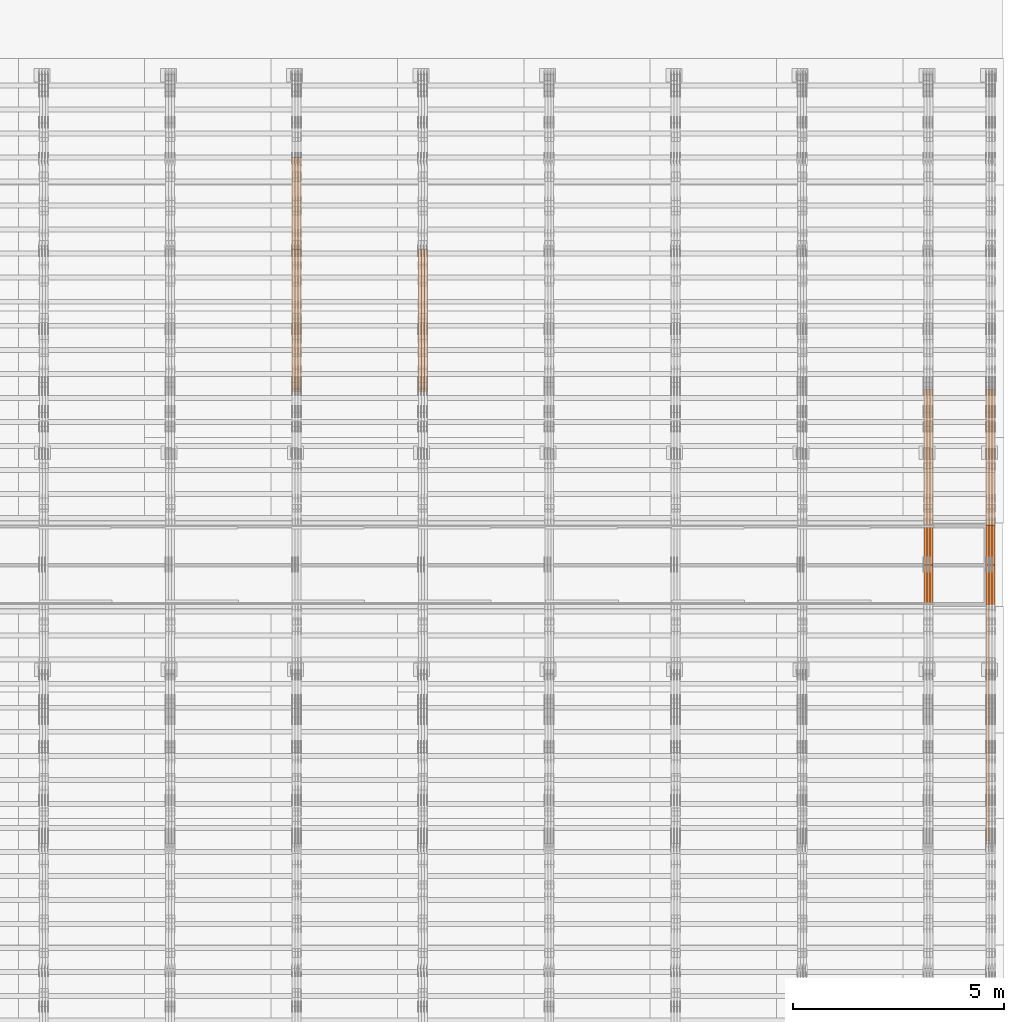
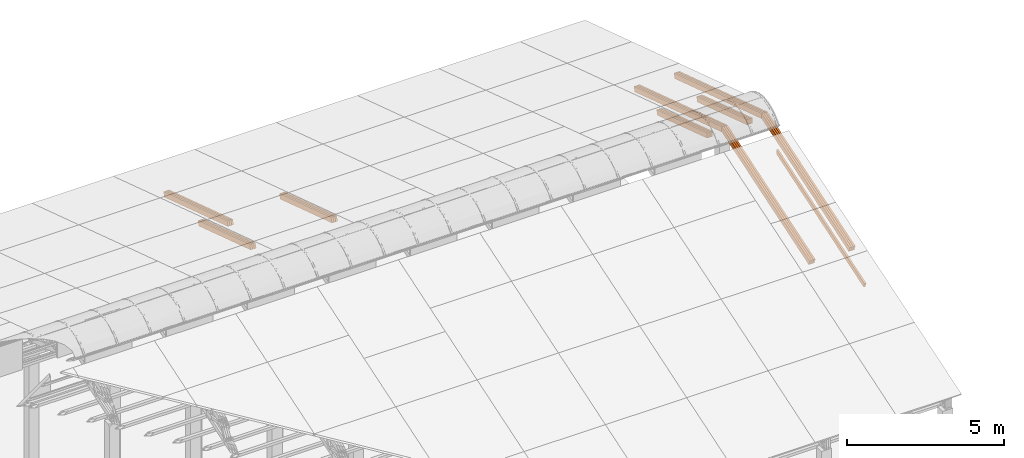
# One storey, part 29 of 385: 28 proxies.
"""IFC2X3 building model written with IfcOpenShell, lengths in millimetres."""

from ifc_helpers import new_model, entity, si_unit, converted_unit, derived_unit, direction, frame, origin, place, context, subcontext, project, spatial, polyline, outline, extrude, source, transform, mapped, material, type_object, type_shapes, element, save


model = new_model("IFC2X3")

# Units and contexts
model_context = context("Model", 3, precision=0.01, world=origin(), true_north=direction((6.12303176911189e-17, 1.0)))
body_context = subcontext(model_context, "Body", "Model", "MODEL_VIEW")
ifc_project = project(units=[si_unit("LENGTHUNIT", "METRE", prefix="MILLI"), si_unit("AREAUNIT", "SQUARE_METRE"), si_unit("VOLUMEUNIT", "CUBIC_METRE"), converted_unit("PLANEANGLEUNIT", "DEGREE", entity("IfcRatioMeasure", 0.0174532925199433), si_unit("PLANEANGLEUNIT", "RADIAN"), dimensions=[0, 0, 0, 0, 0, 0, 0]), si_unit("MASSUNIT", "GRAM", prefix="KILO"), derived_unit("MASSDENSITYUNIT", [(si_unit("MASSUNIT", "GRAM", prefix="KILO"), 1), (si_unit("LENGTHUNIT", "METRE"), -3)]), si_unit("TIMEUNIT", "SECOND"), si_unit("FREQUENCYUNIT", "HERTZ"), si_unit("THERMODYNAMICTEMPERATUREUNIT", "DEGREE_CELSIUS"), derived_unit("THERMALTRANSMITTANCEUNIT", [(si_unit("MASSUNIT", "GRAM", prefix="KILO"), 1), (si_unit("THERMODYNAMICTEMPERATUREUNIT", "KELVIN"), -1), (si_unit("TIMEUNIT", "SECOND"), -3)]), derived_unit("VOLUMETRICFLOWRATEUNIT", [(si_unit("LENGTHUNIT", "METRE"), 3), (si_unit("TIMEUNIT", "SECOND"), -1)]), si_unit("ELECTRICCURRENTUNIT", "AMPERE"), si_unit("ELECTRICVOLTAGEUNIT", "VOLT"), si_unit("POWERUNIT", "WATT"), si_unit("FORCEUNIT", "NEWTON", prefix="KILO"), si_unit("ILLUMINANCEUNIT", "LUX"), si_unit("LUMINOUSFLUXUNIT", "LUMEN"), si_unit("LUMINOUSINTENSITYUNIT", "CANDELA"), derived_unit("USERDEFINED", [(si_unit("MASSUNIT", "GRAM", prefix="KILO"), -1), (si_unit("LENGTHUNIT", "METRE"), -2), (si_unit("TIMEUNIT", "SECOND"), 3), (si_unit("LUMINOUSFLUXUNIT", "LUMEN"), 1)]), derived_unit("LINEARVELOCITYUNIT", [(si_unit("LENGTHUNIT", "METRE"), 1), (si_unit("TIMEUNIT", "SECOND"), -1)]), si_unit("PRESSUREUNIT", "PASCAL"), derived_unit("USERDEFINED", [(si_unit("LENGTHUNIT", "METRE"), -2), (si_unit("MASSUNIT", "GRAM", prefix="KILO"), 1), (si_unit("TIMEUNIT", "SECOND"), -2)])], contexts=[model_context])

# Site, building, storey
site_placement = place(None, origin())
site = spatial("IfcSite", under=ifc_project, at=site_placement, CompositionType="ELEMENT")
building_placement = place(site_placement, origin())
building = spatial("IfcBuilding", under=site, at=building_placement, CompositionType="ELEMENT")
storey_placement = place(building_placement, origin())
storey = spatial("IfcBuildingStorey", under=building, at=storey_placement, Name="Default", CompositionType="ELEMENT", Elevation=0.0)

# Proxies
ifc_material_1 = material(Name="IfcSurfaceStyle #593704")
building_element_proxy_type_1 = type_object("IfcBuildingElementProxyType", Name="T2-T1 593702", PredefinedType="NOTDEFINED", material=ifc_material_1)
shared_shape_1 = source(origin(), body_context, "Body", "SweptSolid", [
    extrude(outline(polyline([(-2970.52406677137, -97.5001477982598), (2938.84461360547, -97.5001477982598), (2938.8441722117, 97.5001477982599), (-2907.1647190458, 97.5001477982598), (-2970.52406677137, -97.5001477982598)])), frame((2938.84461360547, 97.5001477982598, 0.0), z_axis=(0.0, 0.0, 1.0), x_axis=(-1.0, 0.0, 0.0)), (0.0, 0.0, 1.0), 69.9999999999996),
])
type_shapes(building_element_proxy_type_1, [shared_shape_1])
proxy_1_placement = place(building_placement, frame((49860.0, 20279.8851854154, 2416.0025491487), z_axis=(-1.0, 0.0, 0.0), x_axis=(0.0, -0.951056516295154, 0.309016994374948)))
element("IfcBuildingElementProxy", 1, at=proxy_1_placement, inside=storey, type_object=building_element_proxy_type_1, material=ifc_material_1, Name="T2-T1", context=body_context, shape_type="MappedRepresentation", body=[
    mapped(shared_shape_1, transform((0.0, 0.0, 0.0), scale=1.0)),
])
ifc_material_2 = material(Name="IfcSurfaceStyle #593647")
building_element_proxy_type_2 = type_object("IfcBuildingElementProxyType", Name="T2-T1 593645", PredefinedType="NOTDEFINED", material=ifc_material_2)
shared_shape_2 = source(origin(), body_context, "Body", "SweptSolid", [
    extrude(outline(polyline([(-2970.52406677137, -97.5001477982598), (2938.84461360547, -97.5001477982598), (2938.8441722117, 97.5001477982599), (-2907.1647190458, 97.5001477982598), (-2970.52406677137, -97.5001477982598)])), frame((2938.84461360547, 97.5001477982598, 0.0), z_axis=(0.0, 0.0, 1.0), x_axis=(-1.0, 0.0, 0.0)), (0.0, 0.0, 1.0), 69.9999999999996),
])
type_shapes(building_element_proxy_type_2, [shared_shape_2])
proxy_2_placement = place(building_placement, frame((49790.0, 20279.8851854154, 2416.0025491487), z_axis=(-1.0, 0.0, 0.0), x_axis=(0.0, -0.951056516295154, 0.309016994374948)))
element("IfcBuildingElementProxy", 2, at=proxy_2_placement, inside=storey, type_object=building_element_proxy_type_2, material=ifc_material_2, Name="T2-T1", context=body_context, shape_type="MappedRepresentation", body=[
    mapped(shared_shape_2, transform((0.0, 0.0, 0.0), scale=1.0)),
])
ifc_material_3 = material(Name="IfcSurfaceStyle #593590")
building_element_proxy_type_3 = type_object("IfcBuildingElementProxyType", Name="T2-T1 593588", PredefinedType="NOTDEFINED", material=ifc_material_3)
shared_shape_3 = source(origin(), body_context, "Body", "SweptSolid", [
    extrude(outline(polyline([(-2970.52406677137, -97.5001477982598), (2938.84461360547, -97.5001477982598), (2938.8441722117, 97.5001477982599), (-2907.1647190458, 97.5001477982598), (-2970.52406677137, -97.5001477982598)])), frame((2938.84461360547, 97.5001477982598, 0.0), z_axis=(0.0, 0.0, 1.0), x_axis=(-1.0, 0.0, 0.0)), (0.0, 0.0, 1.0), 69.9999999999996),
])
type_shapes(building_element_proxy_type_3, [shared_shape_3])
proxy_3_placement = place(building_placement, frame((49720.0, 20279.8851854154, 2416.0025491487), z_axis=(-1.0, 0.0, 0.0), x_axis=(0.0, -0.951056516295154, 0.309016994374948)))
element("IfcBuildingElementProxy", 3, at=proxy_3_placement, inside=storey, type_object=building_element_proxy_type_3, material=ifc_material_3, Name="T2-T1", context=body_context, shape_type="MappedRepresentation", body=[
    mapped(shared_shape_3, transform((0.0, 0.0, 0.0), scale=1.0)),
])
ifc_material_4 = material(Name="IfcSurfaceStyle #592849")
building_element_proxy_type_4 = type_object("IfcBuildingElementProxyType", Name="T2-T1 592847", PredefinedType="NOTDEFINED", material=ifc_material_4)
shared_shape_4 = source(origin(), body_context, "Body", "SweptSolid", [
    extrude(outline(polyline([(-2938.84391703088, -97.499801613968), (2970.52383457984, -97.499801613968), (2907.16448685427, 97.499801613968), (-2938.84440440323, 97.499801613968), (-2938.84391703088, -97.499801613968)])), frame((2970.52383457984, 97.5000757893295, 0.0), z_axis=(0.0, 0.0, 1.0), x_axis=(-1.0, 0.0, 0.0)), (0.0, 0.0, 1.0), 69.9999999999996),
])
type_shapes(building_element_proxy_type_4, [shared_shape_4])
proxy_4_placement = place(building_placement, frame((49860.0, 14780.2584052475, 4242.0978974122), z_axis=(-1.0, 0.0, 0.0), x_axis=(0.0, -0.951056516295154, -0.309016994374948)))
element("IfcBuildingElementProxy", 4, at=proxy_4_placement, inside=storey, type_object=building_element_proxy_type_4, material=ifc_material_4, Name="T2-T1", context=body_context, shape_type="MappedRepresentation", body=[
    mapped(shared_shape_4, transform((0.0, 0.0, 0.0), scale=1.0)),
])
ifc_material_5 = material(Name="IfcSurfaceStyle #592792")
building_element_proxy_type_5 = type_object("IfcBuildingElementProxyType", Name="T2-T1 592790", PredefinedType="NOTDEFINED", material=ifc_material_5)
shared_shape_5 = source(origin(), body_context, "Body", "SweptSolid", [
    extrude(outline(polyline([(-2938.84391703088, -97.499801613968), (2970.52383457984, -97.499801613968), (2907.16448685427, 97.499801613968), (-2938.84440440323, 97.499801613968), (-2938.84391703088, -97.499801613968)])), frame((2970.52383457984, 97.5000757893295, 0.0), z_axis=(0.0, 0.0, 1.0), x_axis=(-1.0, 0.0, 0.0)), (0.0, 0.0, 1.0), 69.9999999999996),
])
type_shapes(building_element_proxy_type_5, [shared_shape_5])
proxy_5_placement = place(building_placement, frame((49790.0, 14780.2584052475, 4242.0978974122), z_axis=(-1.0, 0.0, 0.0), x_axis=(0.0, -0.951056516295154, -0.309016994374948)))
element("IfcBuildingElementProxy", 5, at=proxy_5_placement, inside=storey, type_object=building_element_proxy_type_5, material=ifc_material_5, Name="T2-T1", context=body_context, shape_type="MappedRepresentation", body=[
    mapped(shared_shape_5, transform((0.0, 0.0, 0.0), scale=1.0)),
])
ifc_material_6 = material(Name="IfcSurfaceStyle #592735")
building_element_proxy_type_6 = type_object("IfcBuildingElementProxyType", Name="T2-T1 592733", PredefinedType="NOTDEFINED", material=ifc_material_6)
shared_shape_6 = source(origin(), body_context, "Body", "SweptSolid", [
    extrude(outline(polyline([(-2938.84391703088, -97.499801613968), (2970.52383457984, -97.499801613968), (2907.16448685427, 97.499801613968), (-2938.84440440323, 97.499801613968), (-2938.84391703088, -97.499801613968)])), frame((2970.52383457984, 97.5000757893295, 0.0), z_axis=(0.0, 0.0, 1.0), x_axis=(-1.0, 0.0, 0.0)), (0.0, 0.0, 1.0), 69.9999999999996),
])
type_shapes(building_element_proxy_type_6, [shared_shape_6])
proxy_6_placement = place(building_placement, frame((49720.0, 14780.2584052475, 4242.0978974122), z_axis=(-1.0, 0.0, 0.0), x_axis=(0.0, -0.951056516295154, -0.309016994374948)))
element("IfcBuildingElementProxy", 6, at=proxy_6_placement, inside=storey, type_object=building_element_proxy_type_6, material=ifc_material_6, Name="T2-T1", context=body_context, shape_type="MappedRepresentation", body=[
    mapped(shared_shape_6, transform((0.0, 0.0, 0.0), scale=1.0)),
])
ifc_material_7 = material(Name="IfcSurfaceStyle #592564")
building_element_proxy_type_7 = type_object("IfcBuildingElementProxyType", Name="T2-B4 592562", PredefinedType="NOTDEFINED", material=ifc_material_7)
shared_shape_7 = source(origin(), body_context, "Body", "SweptSolid", [
    extrude(outline(polyline([(-2912.13310129284, -85.0000958683222), (2939.75111293783, -85.0000958683222), (2939.75142473078, 85.0000958683222), (-2967.36943637577, 85.0000958683222), (-2912.13310129284, -85.0000958683222)])), frame((2939.75142473078, 85.0000958683222, 0.0), z_axis=(0.0, 0.0, 1.0), x_axis=(-1.0, 0.0, 0.0)), (0.0, 0.0, 1.0), 69.9999999999996),
])
type_shapes(building_element_proxy_type_7, [shared_shape_7])
proxy_7_placement = place(building_placement, frame((49720.0, 8161.994140625, 1765.00476074219), z_axis=(-1.0, 0.0, 0.0), x_axis=(0.0, 0.951056516295124, 0.309016994375039)))
element("IfcBuildingElementProxy", 7, at=proxy_7_placement, inside=storey, type_object=building_element_proxy_type_7, material=ifc_material_7, Name="T2-B4", context=body_context, shape_type="MappedRepresentation", body=[
    mapped(shared_shape_7, transform((0.0, 0.0, 0.0), scale=1.0)),
])
ifc_material_8 = material(Name="IfcSurfaceStyle #592309")
building_element_proxy_type_8 = type_object("IfcBuildingElementProxyType", Name="T2-B3 592307", PredefinedType="NOTDEFINED", material=ifc_material_8)
shared_shape_8 = source(origin(), body_context, "Body", "SweptSolid", [
    extrude(outline(polyline([(-1715.8757175801, -97.4999653079672), (1684.19580003112, -97.4999653079672), (1684.19628740349, 97.4999653079672), (-1652.51636985451, 97.4999653079672), (-1715.8757175801, -97.4999653079672)])), frame((1684.19628740349, 97.5000561131842, 0.0), z_axis=(0.0, 0.0, 1.0), x_axis=(-1.0, 0.0, 0.0)), (0.0, 0.0, 1.0), 69.9999999999998),
])
type_shapes(building_element_proxy_type_8, [shared_shape_8])
proxy_8_placement = place(building_placement, frame((49860.0, 18833.4023156896, 2380.55582184223), z_axis=(-1.0, 0.0, 0.0), x_axis=(0.0, -0.951056516295124, 0.309016994375039)))
element("IfcBuildingElementProxy", 8, at=proxy_8_placement, inside=storey, type_object=building_element_proxy_type_8, material=ifc_material_8, Name="T2-B3", context=body_context, shape_type="MappedRepresentation", body=[
    mapped(shared_shape_8, transform((0.0, 0.0, 0.0), scale=1.0)),
])
ifc_material_9 = material(Name="IfcSurfaceStyle #592252")
building_element_proxy_type_9 = type_object("IfcBuildingElementProxyType", Name="T2-B3 592250", PredefinedType="NOTDEFINED", material=ifc_material_9)
shared_shape_9 = source(origin(), body_context, "Body", "SweptSolid", [
    extrude(outline(polyline([(-1715.8757175801, -97.4999653079672), (1684.19580003112, -97.4999653079672), (1684.19628740349, 97.4999653079672), (-1652.51636985451, 97.4999653079672), (-1715.8757175801, -97.4999653079672)])), frame((1684.19628740349, 97.5000561131842, 0.0), z_axis=(0.0, 0.0, 1.0), x_axis=(-1.0, 0.0, 0.0)), (0.0, 0.0, 1.0), 69.9999999999998),
])
type_shapes(building_element_proxy_type_9, [shared_shape_9])
proxy_9_placement = place(building_placement, frame((49790.0, 18833.4023156896, 2380.55582184223), z_axis=(-1.0, 0.0, 0.0), x_axis=(0.0, -0.951056516295124, 0.309016994375039)))
element("IfcBuildingElementProxy", 9, at=proxy_9_placement, inside=storey, type_object=building_element_proxy_type_9, material=ifc_material_9, Name="T2-B3", context=body_context, shape_type="MappedRepresentation", body=[
    mapped(shared_shape_9, transform((0.0, 0.0, 0.0), scale=1.0)),
])
ifc_material_10 = material(Name="IfcSurfaceStyle #592195")
building_element_proxy_type_10 = type_object("IfcBuildingElementProxyType", Name="T2-B3 592193", PredefinedType="NOTDEFINED", material=ifc_material_10)
shared_shape_10 = source(origin(), body_context, "Body", "SweptSolid", [
    extrude(outline(polyline([(-1715.8757175801, -97.4999653079672), (1684.19580003112, -97.4999653079672), (1684.19628740349, 97.4999653079672), (-1652.51636985451, 97.4999653079672), (-1715.8757175801, -97.4999653079672)])), frame((1684.19628740349, 97.5000561131842, 0.0), z_axis=(0.0, 0.0, 1.0), x_axis=(-1.0, 0.0, 0.0)), (0.0, 0.0, 1.0), 69.9999999999998),
])
type_shapes(building_element_proxy_type_10, [shared_shape_10])
proxy_10_placement = place(building_placement, frame((49720.0, 18833.4023156896, 2380.55582184223), z_axis=(-1.0, 0.0, 0.0), x_axis=(0.0, -0.951056516295124, 0.309016994375039)))
element("IfcBuildingElementProxy", 10, at=proxy_10_placement, inside=storey, type_object=building_element_proxy_type_10, material=ifc_material_10, Name="T2-B3", context=body_context, shape_type="MappedRepresentation", body=[
    mapped(shared_shape_10, transform((0.0, 0.0, 0.0), scale=1.0)),
])
ifc_material_11 = material(Name="IfcSurfaceStyle #559272")
building_element_proxy_type_11 = type_object("IfcBuildingElementProxyType", Name="T1-T1 559270", PredefinedType="NOTDEFINED", material=ifc_material_11)
shared_shape_11 = source(origin(), body_context, "Body", "SweptSolid", [
    extrude(outline(polyline([(-2970.52406677137, -97.5001477982598), (2938.84461360547, -97.5001477982598), (2938.8441722117, 97.5001477982599), (-2907.1647190458, 97.5001477982598), (-2970.52406677137, -97.5001477982598)])), frame((2938.84461360547, 97.5001477982598, 0.0), z_axis=(0.0, 0.0, 1.0), x_axis=(-1.0, 0.0, 0.0)), (0.0, 0.0, 1.0), 69.9999999999996),
])
type_shapes(building_element_proxy_type_11, [shared_shape_11])
proxy_11_placement = place(building_placement, frame((48385.0, 20279.8851854154, 2416.0025491487), z_axis=(-1.0, 0.0, 0.0), x_axis=(0.0, -0.951056516295154, 0.309016994374948)))
element("IfcBuildingElementProxy", 11, at=proxy_11_placement, inside=storey, type_object=building_element_proxy_type_11, material=ifc_material_11, Name="T1-T1", context=body_context, shape_type="MappedRepresentation", body=[
    mapped(shared_shape_11, transform((0.0, 0.0, 0.0), scale=1.0)),
])
ifc_material_12 = material(Name="IfcSurfaceStyle #559215")
building_element_proxy_type_12 = type_object("IfcBuildingElementProxyType", Name="T1-T1 559213", PredefinedType="NOTDEFINED", material=ifc_material_12)
shared_shape_12 = source(origin(), body_context, "Body", "SweptSolid", [
    extrude(outline(polyline([(-2970.52406677137, -97.5001477982598), (2938.84461360547, -97.5001477982598), (2938.8441722117, 97.5001477982599), (-2907.1647190458, 97.5001477982598), (-2970.52406677137, -97.5001477982598)])), frame((2938.84461360547, 97.5001477982598, 0.0), z_axis=(0.0, 0.0, 1.0), x_axis=(-1.0, 0.0, 0.0)), (0.0, 0.0, 1.0), 69.9999999999996),
])
type_shapes(building_element_proxy_type_12, [shared_shape_12])
proxy_12_placement = place(building_placement, frame((48315.0, 20279.8851854154, 2416.0025491487), z_axis=(-1.0, 0.0, 0.0), x_axis=(0.0, -0.951056516295154, 0.309016994374948)))
element("IfcBuildingElementProxy", 12, at=proxy_12_placement, inside=storey, type_object=building_element_proxy_type_12, material=ifc_material_12, Name="T1-T1", context=body_context, shape_type="MappedRepresentation", body=[
    mapped(shared_shape_12, transform((0.0, 0.0, 0.0), scale=1.0)),
])
ifc_material_13 = material(Name="IfcSurfaceStyle #559158")
building_element_proxy_type_13 = type_object("IfcBuildingElementProxyType", Name="T1-T1 559156", PredefinedType="NOTDEFINED", material=ifc_material_13)
shared_shape_13 = source(origin(), body_context, "Body", "SweptSolid", [
    extrude(outline(polyline([(-2970.52406677137, -97.5001477982598), (2938.84461360547, -97.5001477982598), (2938.8441722117, 97.5001477982599), (-2907.1647190458, 97.5001477982598), (-2970.52406677137, -97.5001477982598)])), frame((2938.84461360547, 97.5001477982598, 0.0), z_axis=(0.0, 0.0, 1.0), x_axis=(-1.0, 0.0, 0.0)), (0.0, 0.0, 1.0), 69.9999999999996),
])
type_shapes(building_element_proxy_type_13, [shared_shape_13])
proxy_13_placement = place(building_placement, frame((48245.0, 20279.8851854154, 2416.0025491487), z_axis=(-1.0, 0.0, 0.0), x_axis=(0.0, -0.951056516295154, 0.309016994374948)))
element("IfcBuildingElementProxy", 13, at=proxy_13_placement, inside=storey, type_object=building_element_proxy_type_13, material=ifc_material_13, Name="T1-T1", context=body_context, shape_type="MappedRepresentation", body=[
    mapped(shared_shape_13, transform((0.0, 0.0, 0.0), scale=1.0)),
])
ifc_material_14 = material(Name="IfcSurfaceStyle #558417")
building_element_proxy_type_14 = type_object("IfcBuildingElementProxyType", Name="T1-T1 558415", PredefinedType="NOTDEFINED", material=ifc_material_14)
shared_shape_14 = source(origin(), body_context, "Body", "SweptSolid", [
    extrude(outline(polyline([(-2938.84391703088, -97.499801613968), (2970.52383457984, -97.499801613968), (2907.16448685427, 97.499801613968), (-2938.84440440323, 97.499801613968), (-2938.84391703088, -97.499801613968)])), frame((2970.52383457984, 97.5000757893295, 0.0), z_axis=(0.0, 0.0, 1.0), x_axis=(-1.0, 0.0, 0.0)), (0.0, 0.0, 1.0), 69.9999999999996),
])
type_shapes(building_element_proxy_type_14, [shared_shape_14])
proxy_14_placement = place(building_placement, frame((48385.0, 14780.2584052475, 4242.0978974122), z_axis=(-1.0, 0.0, 0.0), x_axis=(0.0, -0.951056516295154, -0.309016994374948)))
element("IfcBuildingElementProxy", 14, at=proxy_14_placement, inside=storey, type_object=building_element_proxy_type_14, material=ifc_material_14, Name="T1-T1", context=body_context, shape_type="MappedRepresentation", body=[
    mapped(shared_shape_14, transform((0.0, 0.0, 0.0), scale=1.0)),
])
ifc_material_15 = material(Name="IfcSurfaceStyle #558360")
building_element_proxy_type_15 = type_object("IfcBuildingElementProxyType", Name="T1-T1 558358", PredefinedType="NOTDEFINED", material=ifc_material_15)
shared_shape_15 = source(origin(), body_context, "Body", "SweptSolid", [
    extrude(outline(polyline([(-2938.84391703088, -97.499801613968), (2970.52383457984, -97.499801613968), (2907.16448685427, 97.499801613968), (-2938.84440440323, 97.499801613968), (-2938.84391703088, -97.499801613968)])), frame((2970.52383457984, 97.5000757893295, 0.0), z_axis=(0.0, 0.0, 1.0), x_axis=(-1.0, 0.0, 0.0)), (0.0, 0.0, 1.0), 69.9999999999996),
])
type_shapes(building_element_proxy_type_15, [shared_shape_15])
proxy_15_placement = place(building_placement, frame((48315.0, 14780.2584052475, 4242.0978974122), z_axis=(-1.0, 0.0, 0.0), x_axis=(0.0, -0.951056516295154, -0.309016994374948)))
element("IfcBuildingElementProxy", 15, at=proxy_15_placement, inside=storey, type_object=building_element_proxy_type_15, material=ifc_material_15, Name="T1-T1", context=body_context, shape_type="MappedRepresentation", body=[
    mapped(shared_shape_15, transform((0.0, 0.0, 0.0), scale=1.0)),
])
ifc_material_16 = material(Name="IfcSurfaceStyle #558303")
building_element_proxy_type_16 = type_object("IfcBuildingElementProxyType", Name="T1-T1 558301", PredefinedType="NOTDEFINED", material=ifc_material_16)
shared_shape_16 = source(origin(), body_context, "Body", "SweptSolid", [
    extrude(outline(polyline([(-2938.84391703088, -97.499801613968), (2970.52383457984, -97.499801613968), (2907.16448685427, 97.499801613968), (-2938.84440440323, 97.499801613968), (-2938.84391703088, -97.499801613968)])), frame((2970.52383457984, 97.5000757893295, 0.0), z_axis=(0.0, 0.0, 1.0), x_axis=(-1.0, 0.0, 0.0)), (0.0, 0.0, 1.0), 69.9999999999996),
])
type_shapes(building_element_proxy_type_16, [shared_shape_16])
proxy_16_placement = place(building_placement, frame((48245.0, 14780.2584052475, 4242.0978974122), z_axis=(-1.0, 0.0, 0.0), x_axis=(0.0, -0.951056516295154, -0.309016994374948)))
element("IfcBuildingElementProxy", 16, at=proxy_16_placement, inside=storey, type_object=building_element_proxy_type_16, material=ifc_material_16, Name="T1-T1", context=body_context, shape_type="MappedRepresentation", body=[
    mapped(shared_shape_16, transform((0.0, 0.0, 0.0), scale=1.0)),
])
ifc_material_17 = material(Name="IfcSurfaceStyle #557877")
building_element_proxy_type_17 = type_object("IfcBuildingElementProxyType", Name="T1-B3 557875", PredefinedType="NOTDEFINED", material=ifc_material_17)
shared_shape_17 = source(origin(), body_context, "Body", "SweptSolid", [
    extrude(outline(polyline([(-1715.8757175801, -97.4999653079672), (1684.19580003112, -97.4999653079672), (1684.19628740349, 97.4999653079672), (-1652.51636985451, 97.4999653079672), (-1715.8757175801, -97.4999653079672)])), frame((1684.19628740349, 97.5000561131842, 0.0), z_axis=(0.0, 0.0, 1.0), x_axis=(-1.0, 0.0, 0.0)), (0.0, 0.0, 1.0), 69.9999999999998),
])
type_shapes(building_element_proxy_type_17, [shared_shape_17])
proxy_17_placement = place(building_placement, frame((48385.0, 18833.4023156897, 2380.55582184223), z_axis=(-1.0, 0.0, 0.0), x_axis=(0.0, -0.951056516295124, 0.309016994375039)))
element("IfcBuildingElementProxy", 17, at=proxy_17_placement, inside=storey, type_object=building_element_proxy_type_17, material=ifc_material_17, Name="T1-B3", context=body_context, shape_type="MappedRepresentation", body=[
    mapped(shared_shape_17, transform((0.0, 0.0, 0.0), scale=1.0)),
])
ifc_material_18 = material(Name="IfcSurfaceStyle #557820")
building_element_proxy_type_18 = type_object("IfcBuildingElementProxyType", Name="T1-B3 557818", PredefinedType="NOTDEFINED", material=ifc_material_18)
shared_shape_18 = source(origin(), body_context, "Body", "SweptSolid", [
    extrude(outline(polyline([(-1715.8757175801, -97.4999653079672), (1684.19580003112, -97.4999653079672), (1684.19628740349, 97.4999653079672), (-1652.51636985451, 97.4999653079672), (-1715.8757175801, -97.4999653079672)])), frame((1684.19628740349, 97.5000561131842, 0.0), z_axis=(0.0, 0.0, 1.0), x_axis=(-1.0, 0.0, 0.0)), (0.0, 0.0, 1.0), 69.9999999999998),
])
type_shapes(building_element_proxy_type_18, [shared_shape_18])
proxy_18_placement = place(building_placement, frame((48315.0, 18833.4023156897, 2380.55582184223), z_axis=(-1.0, 0.0, 0.0), x_axis=(0.0, -0.951056516295124, 0.309016994375039)))
element("IfcBuildingElementProxy", 18, at=proxy_18_placement, inside=storey, type_object=building_element_proxy_type_18, material=ifc_material_18, Name="T1-B3", context=body_context, shape_type="MappedRepresentation", body=[
    mapped(shared_shape_18, transform((0.0, 0.0, 0.0), scale=1.0)),
])
ifc_material_19 = material(Name="IfcSurfaceStyle #557763")
building_element_proxy_type_19 = type_object("IfcBuildingElementProxyType", Name="T1-B3 557761", PredefinedType="NOTDEFINED", material=ifc_material_19)
shared_shape_19 = source(origin(), body_context, "Body", "SweptSolid", [
    extrude(outline(polyline([(-1715.8757175801, -97.4999653079672), (1684.19580003112, -97.4999653079672), (1684.19628740349, 97.4999653079672), (-1652.51636985451, 97.4999653079672), (-1715.8757175801, -97.4999653079672)])), frame((1684.19628740349, 97.5000561131842, 0.0), z_axis=(0.0, 0.0, 1.0), x_axis=(-1.0, 0.0, 0.0)), (0.0, 0.0, 1.0), 69.9999999999998),
])
type_shapes(building_element_proxy_type_19, [shared_shape_19])
proxy_19_placement = place(building_placement, frame((48245.0, 18833.4023156897, 2380.55582184223), z_axis=(-1.0, 0.0, 0.0), x_axis=(0.0, -0.951056516295124, 0.309016994375039)))
element("IfcBuildingElementProxy", 19, at=proxy_19_placement, inside=storey, type_object=building_element_proxy_type_19, material=ifc_material_19, Name="T1-B3", context=body_context, shape_type="MappedRepresentation", body=[
    mapped(shared_shape_19, transform((0.0, 0.0, 0.0), scale=1.0)),
])
ifc_material_20 = material(Name="IfcSurfaceStyle #419978")
building_element_proxy_type_20 = type_object("IfcBuildingElementProxyType", Name="T1-B2 419976", PredefinedType="NOTDEFINED", material=ifc_material_20)
shared_shape_20 = source(origin(), body_context, "Body", "SweptSolid", [
    extrude(outline(polyline([(-1738.61933402934, -97.4999466901035), (1738.6190788485, -97.4999466901035), (1738.6191018378, 97.4999466901035), (-1738.61884665697, 97.4999466901035), (-1738.61933402934, -97.4999466901035)])), frame((1738.6191018378, 97.4999528847471, 0.0), z_axis=(0.0, 0.0, 1.0), x_axis=(-1.0, 0.0, 0.0)), (0.0, 0.0, 1.0), 69.9999999999998),
])
type_shapes(building_element_proxy_type_20, [shared_shape_20])
proxy_20_placement = place(building_placement, frame((36385.0, 22140.4521465233, 1306.03026754604), z_axis=(-1.0, 0.0, 0.0), x_axis=(0.0, -0.951056516295124, 0.309016994375039)))
element("IfcBuildingElementProxy", 20, at=proxy_20_placement, inside=storey, type_object=building_element_proxy_type_20, material=ifc_material_20, Name="T1-B2", context=body_context, shape_type="MappedRepresentation", body=[
    mapped(shared_shape_20, transform((0.0, 0.0, 0.0), scale=1.0)),
])
ifc_material_21 = material(Name="IfcSurfaceStyle #419921")
building_element_proxy_type_21 = type_object("IfcBuildingElementProxyType", Name="T1-B2 419919", PredefinedType="NOTDEFINED", material=ifc_material_21)
shared_shape_21 = source(origin(), body_context, "Body", "SweptSolid", [
    extrude(outline(polyline([(-1738.61933402934, -97.4999466901035), (1738.6190788485, -97.4999466901035), (1738.6191018378, 97.4999466901035), (-1738.61884665697, 97.4999466901035), (-1738.61933402934, -97.4999466901035)])), frame((1738.6191018378, 97.4999528847471, 0.0), z_axis=(0.0, 0.0, 1.0), x_axis=(-1.0, 0.0, 0.0)), (0.0, 0.0, 1.0), 69.9999999999998),
])
type_shapes(building_element_proxy_type_21, [shared_shape_21])
proxy_21_placement = place(building_placement, frame((36315.0, 22140.4521465233, 1306.03026754604), z_axis=(-1.0, 0.0, 0.0), x_axis=(0.0, -0.951056516295124, 0.309016994375039)))
element("IfcBuildingElementProxy", 21, at=proxy_21_placement, inside=storey, type_object=building_element_proxy_type_21, material=ifc_material_21, Name="T1-B2", context=body_context, shape_type="MappedRepresentation", body=[
    mapped(shared_shape_21, transform((0.0, 0.0, 0.0), scale=1.0)),
])
ifc_material_22 = material(Name="IfcSurfaceStyle #419864")
building_element_proxy_type_22 = type_object("IfcBuildingElementProxyType", Name="T1-B2 419862", PredefinedType="NOTDEFINED", material=ifc_material_22)
shared_shape_22 = source(origin(), body_context, "Body", "SweptSolid", [
    extrude(outline(polyline([(-1738.61933402934, -97.4999466901035), (1738.6190788485, -97.4999466901035), (1738.6191018378, 97.4999466901035), (-1738.61884665697, 97.4999466901035), (-1738.61933402934, -97.4999466901035)])), frame((1738.6191018378, 97.4999528847471, 0.0), z_axis=(0.0, 0.0, 1.0), x_axis=(-1.0, 0.0, 0.0)), (0.0, 0.0, 1.0), 69.9999999999998),
])
type_shapes(building_element_proxy_type_22, [shared_shape_22])
proxy_22_placement = place(building_placement, frame((36245.0, 22140.4521465233, 1306.03026754604), z_axis=(-1.0, 0.0, 0.0), x_axis=(0.0, -0.951056516295124, 0.309016994375039)))
element("IfcBuildingElementProxy", 22, at=proxy_22_placement, inside=storey, type_object=building_element_proxy_type_22, material=ifc_material_22, Name="T1-B2", context=body_context, shape_type="MappedRepresentation", body=[
    mapped(shared_shape_22, transform((0.0, 0.0, 0.0), scale=1.0)),
])
ifc_material_23 = material(Name="IfcSurfaceStyle #386941")
building_element_proxy_type_23 = type_object("IfcBuildingElementProxyType", Name="T1-T2 386939", PredefinedType="NOTDEFINED", material=ifc_material_23)
shared_shape_23 = source(origin(), body_context, "Body", "SweptSolid", [
    extrude(outline(polyline([(-2137.04373183812, -97.5000250291418), (2137.04394104036, -97.5000250291418), (2137.04396402965, 97.5000250291418), (-2137.04417323189, 97.5000250291418), (-2137.04373183812, -97.5000250291418)])), frame((2137.04396402965, 97.5001541485632, 0.0), z_axis=(0.0, 0.0, 1.0), x_axis=(-1.0, 0.0, 0.0)), (0.0, 0.0, 1.0), 69.9999999999997),
])
type_shapes(building_element_proxy_type_23, [shared_shape_23])
proxy_23_placement = place(building_placement, frame((33385.0, 24344.7841397874, 1095.2368156767), z_axis=(-1.0, 0.0, 0.0), x_axis=(0.0, -0.951056516295154, 0.309016994374948)))
element("IfcBuildingElementProxy", 23, at=proxy_23_placement, inside=storey, type_object=building_element_proxy_type_23, material=ifc_material_23, Name="T1-T2", context=body_context, shape_type="MappedRepresentation", body=[
    mapped(shared_shape_23, transform((0.0, 0.0, 0.0), scale=1.0)),
])
ifc_material_24 = material(Name="IfcSurfaceStyle #386884")
building_element_proxy_type_24 = type_object("IfcBuildingElementProxyType", Name="T1-T2 386882", PredefinedType="NOTDEFINED", material=ifc_material_24)
shared_shape_24 = source(origin(), body_context, "Body", "SweptSolid", [
    extrude(outline(polyline([(-2137.04373183812, -97.5000250291418), (2137.04394104036, -97.5000250291418), (2137.04396402965, 97.5000250291418), (-2137.04417323189, 97.5000250291418), (-2137.04373183812, -97.5000250291418)])), frame((2137.04396402965, 97.5001541485632, 0.0), z_axis=(0.0, 0.0, 1.0), x_axis=(-1.0, 0.0, 0.0)), (0.0, 0.0, 1.0), 69.9999999999997),
])
type_shapes(building_element_proxy_type_24, [shared_shape_24])
proxy_24_placement = place(building_placement, frame((33315.0, 24344.7841397874, 1095.2368156767), z_axis=(-1.0, 0.0, 0.0), x_axis=(0.0, -0.951056516295154, 0.309016994374948)))
element("IfcBuildingElementProxy", 24, at=proxy_24_placement, inside=storey, type_object=building_element_proxy_type_24, material=ifc_material_24, Name="T1-T2", context=body_context, shape_type="MappedRepresentation", body=[
    mapped(shared_shape_24, transform((0.0, 0.0, 0.0), scale=1.0)),
])
ifc_material_25 = material(Name="IfcSurfaceStyle #386827")
building_element_proxy_type_25 = type_object("IfcBuildingElementProxyType", Name="T1-T2 386825", PredefinedType="NOTDEFINED", material=ifc_material_25)
shared_shape_25 = source(origin(), body_context, "Body", "SweptSolid", [
    extrude(outline(polyline([(-2137.04373183812, -97.5000250291418), (2137.04394104036, -97.5000250291418), (2137.04396402965, 97.5000250291418), (-2137.04417323189, 97.5000250291418), (-2137.04373183812, -97.5000250291418)])), frame((2137.04396402965, 97.5001541485632, 0.0), z_axis=(0.0, 0.0, 1.0), x_axis=(-1.0, 0.0, 0.0)), (0.0, 0.0, 1.0), 69.9999999999997),
])
type_shapes(building_element_proxy_type_25, [shared_shape_25])
proxy_25_placement = place(building_placement, frame((33245.0, 24344.7841397874, 1095.2368156767), z_axis=(-1.0, 0.0, 0.0), x_axis=(0.0, -0.951056516295154, 0.309016994374948)))
element("IfcBuildingElementProxy", 25, at=proxy_25_placement, inside=storey, type_object=building_element_proxy_type_25, material=ifc_material_25, Name="T1-T2", context=body_context, shape_type="MappedRepresentation", body=[
    mapped(shared_shape_25, transform((0.0, 0.0, 0.0), scale=1.0)),
])
ifc_material_26 = material(Name="IfcSurfaceStyle #385546")
building_element_proxy_type_26 = type_object("IfcBuildingElementProxyType", Name="T1-B2 385544", PredefinedType="NOTDEFINED", material=ifc_material_26)
shared_shape_26 = source(origin(), body_context, "Body", "SweptSolid", [
    extrude(outline(polyline([(-1738.61933402934, -97.4999466901035), (1738.6190788485, -97.4999466901035), (1738.6191018378, 97.4999466901035), (-1738.61884665697, 97.4999466901035), (-1738.61933402934, -97.4999466901035)])), frame((1738.6191018378, 97.4999528847471, 0.0), z_axis=(0.0, 0.0, 1.0), x_axis=(-1.0, 0.0, 0.0)), (0.0, 0.0, 1.0), 69.9999999999998),
])
type_shapes(building_element_proxy_type_26, [shared_shape_26])
proxy_26_placement = place(building_placement, frame((33385.0, 22140.4521465233, 1306.03026754604), z_axis=(-1.0, 0.0, 0.0), x_axis=(0.0, -0.951056516295124, 0.309016994375039)))
element("IfcBuildingElementProxy", 26, at=proxy_26_placement, inside=storey, type_object=building_element_proxy_type_26, material=ifc_material_26, Name="T1-B2", context=body_context, shape_type="MappedRepresentation", body=[
    mapped(shared_shape_26, transform((0.0, 0.0, 0.0), scale=1.0)),
])
ifc_material_27 = material(Name="IfcSurfaceStyle #385489")
building_element_proxy_type_27 = type_object("IfcBuildingElementProxyType", Name="T1-B2 385487", PredefinedType="NOTDEFINED", material=ifc_material_27)
shared_shape_27 = source(origin(), body_context, "Body", "SweptSolid", [
    extrude(outline(polyline([(-1738.61933402934, -97.4999466901035), (1738.6190788485, -97.4999466901035), (1738.6191018378, 97.4999466901035), (-1738.61884665697, 97.4999466901035), (-1738.61933402934, -97.4999466901035)])), frame((1738.6191018378, 97.4999528847471, 0.0), z_axis=(0.0, 0.0, 1.0), x_axis=(-1.0, 0.0, 0.0)), (0.0, 0.0, 1.0), 69.9999999999998),
])
type_shapes(building_element_proxy_type_27, [shared_shape_27])
proxy_27_placement = place(building_placement, frame((33315.0, 22140.4521465233, 1306.03026754604), z_axis=(-1.0, 0.0, 0.0), x_axis=(0.0, -0.951056516295124, 0.309016994375039)))
element("IfcBuildingElementProxy", 27, at=proxy_27_placement, inside=storey, type_object=building_element_proxy_type_27, material=ifc_material_27, Name="T1-B2", context=body_context, shape_type="MappedRepresentation", body=[
    mapped(shared_shape_27, transform((0.0, 0.0, 0.0), scale=1.0)),
])
ifc_material_28 = material(Name="IfcSurfaceStyle #385432")
building_element_proxy_type_28 = type_object("IfcBuildingElementProxyType", Name="T1-B2 385430", PredefinedType="NOTDEFINED", material=ifc_material_28)
shared_shape_28 = source(origin(), body_context, "Body", "SweptSolid", [
    extrude(outline(polyline([(-1738.61933402934, -97.4999466901035), (1738.6190788485, -97.4999466901035), (1738.6191018378, 97.4999466901035), (-1738.61884665697, 97.4999466901035), (-1738.61933402934, -97.4999466901035)])), frame((1738.6191018378, 97.4999528847471, 0.0), z_axis=(0.0, 0.0, 1.0), x_axis=(-1.0, 0.0, 0.0)), (0.0, 0.0, 1.0), 69.9999999999998),
])
type_shapes(building_element_proxy_type_28, [shared_shape_28])
proxy_28_placement = place(building_placement, frame((33245.0, 22140.4521465233, 1306.03026754604), z_axis=(-1.0, 0.0, 0.0), x_axis=(0.0, -0.951056516295124, 0.309016994375039)))
element("IfcBuildingElementProxy", 28, at=proxy_28_placement, inside=storey, type_object=building_element_proxy_type_28, material=ifc_material_28, Name="T1-B2", context=body_context, shape_type="MappedRepresentation", body=[
    mapped(shared_shape_28, transform((0.0, 0.0, 0.0), scale=1.0)),
])

save(model, "model.ifc")
